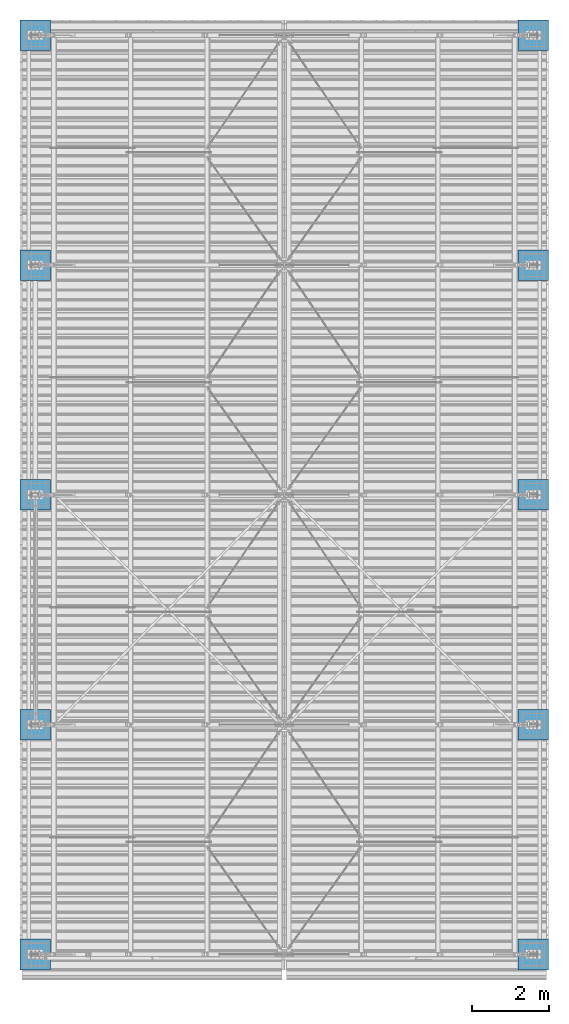
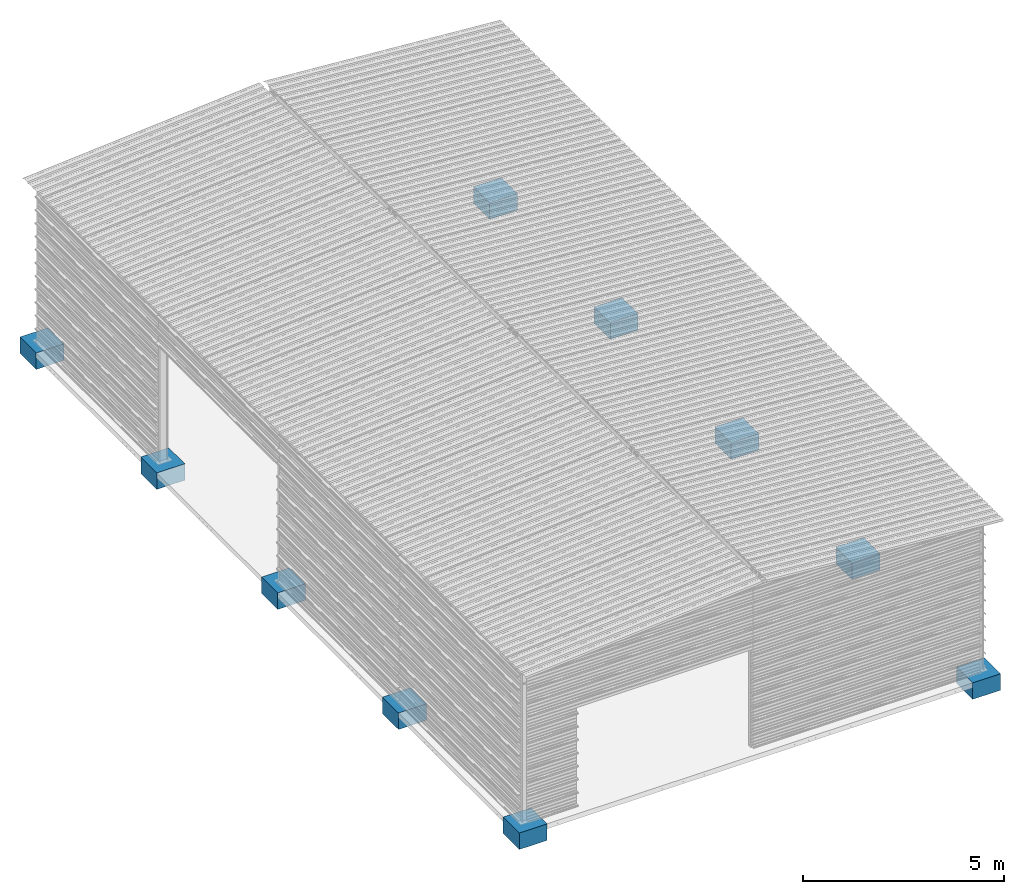
# One storey, part 1 of 70: 10 footings, 10 elements without a shape of their own.
"""IFC2X3 building model written with IfcOpenShell, lengths in millimetres."""

import ifcopenshell
import ifcopenshell.guid

model = None  # the IFC model being written
_history = None  # IfcOwnerHistory: only IFC2X3 demands one
_inside = {}  # id of a spatial element -> (the spatial element, [elements in it])
_under = {}  # id of a project, library or spatial element -> (it, [spatial elements below it])
_declared = {}  # id of a project -> (the project, [libraries it declares])
_typed = {}  # id of a type object -> (the type object, [elements of that type])
_made_of = {}  # id of a material, layer set ... -> (it, [elements and type objects made of it])


def new_model(schema):
    """Start an empty IFC model of exactly this schema.

    Asked for "IFC4X3", IfcOpenShell would pick the latest addendum, in which some entities
    have other attributes; the version numbers below select the first issue.
    IFC2X3 requires an IfcOwnerHistory on every rooted entity: one is made here for all.
    """
    global model, _history
    if schema == "IFC4X3":
        model = ifcopenshell.file(schema_version=(4, 3, 0, 0))
    else:
        model = ifcopenshell.file(schema=schema)
    _inside.clear()
    _under.clear()
    _declared.clear()
    _typed.clear()
    _made_of.clear()
    _history = None
    if model.schema == "IFC2X3":
        org = make("IfcOrganization", Name="unknown")
        user = make(
            "IfcPersonAndOrganization",
            ThePerson=make("IfcPerson", FamilyName="unknown"),
            TheOrganization=org,
        )
        app = make(
            "IfcApplication",
            ApplicationDeveloper=org,
            Version="unknown",
            ApplicationFullName="unknown",
            ApplicationIdentifier="unknown",
        )
        _history = make(
            "IfcOwnerHistory",
            OwningUser=user,
            OwningApplication=app,
            ChangeAction="ADDED",
            CreationDate=0,
        )
    return model


def make(cls, **values):
    """One entity of the class cls with the attributes given. An attribute that is None is left unset."""
    return model.create_entity(
        cls, **{name: value for name, value in values.items() if value is not None}
    )


def rooted(cls, **values):
    """An entity with a GlobalId (a new one), such as an element, a storey or a relation."""
    return make(cls, GlobalId=ifcopenshell.guid.new(), OwnerHistory=_history, **values)


def si_unit(unit_type, name, prefix=None):
    """IfcSIUnit, for example si_unit("LENGTHUNIT", "METRE", prefix="MILLI")."""
    return make("IfcSIUnit", UnitType=unit_type, Prefix=prefix, Name=name)


def assignment(units):
    """IfcUnitAssignment: the units of a project."""
    return None if units is None else make("IfcUnitAssignment", Units=units)


def point(xyz):
    """IfcCartesianPoint."""
    return None if xyz is None else make("IfcCartesianPoint", Coordinates=xyz)


def direction(xyz):
    """IfcDirection."""
    return None if xyz is None else make("IfcDirection", DirectionRatios=xyz)


def frame(location, z_axis=None, x_axis=None):
    """IfcAxis2Placement3D, a coordinate frame: its origin and axes. An axis left out is left unset."""
    return make(
        "IfcAxis2Placement3D",
        Location=point(location),
        Axis=direction(z_axis),
        RefDirection=direction(x_axis),
    )


def frame_2d(location, x_axis=None):
    """IfcAxis2Placement2D, a coordinate frame in the plane: its origin and x axis."""
    return make(
        "IfcAxis2Placement2D", Location=point(location), RefDirection=direction(x_axis)
    )


def origin_with_axes():
    """The frame at (0, 0, 0) with the z axis (0, 0, 1) and the x axis (1, 0, 0) written out."""
    return frame((0.0, 0.0, 0.0), z_axis=(0.0, 0.0, 1.0), x_axis=(1.0, 0.0, 0.0))


def origin_2d_with_axis():
    """The frame at (0, 0) in the plane with the x axis (1, 0) written out."""
    return frame_2d((0.0, 0.0), x_axis=(1.0, 0.0))


def place(relative_to, where):
    """IfcLocalPlacement: puts the frame where relative to a parent placement (None: the world)."""
    return make(
        "IfcLocalPlacement", PlacementRelTo=relative_to, RelativePlacement=where
    )


def context(
    kind, dimensions, precision=None, world=None, true_north=None, identifier=None
):
    """IfcGeometricRepresentationContext, for example the 3D "Model" context."""
    return make(
        "IfcGeometricRepresentationContext",
        ContextIdentifier=identifier,
        ContextType=kind,
        CoordinateSpaceDimension=dimensions,
        Precision=precision,
        WorldCoordinateSystem=world,
        TrueNorth=true_north,
    )


def subcontext(parent, identifier, kind, view, scale=None):
    """IfcGeometricRepresentationSubContext, for example "Body" below "Model"."""
    return make(
        "IfcGeometricRepresentationSubContext",
        ContextIdentifier=identifier,
        ContextType=kind,
        ParentContext=parent,
        TargetScale=scale,
        TargetView=view,
    )


def project(units=None, contexts=None):
    """IfcProject with its units and contexts."""
    return rooted(
        "IfcProject",
        Name="project",
        RepresentationContexts=contexts,
        UnitsInContext=assignment(units),
    )


def spatial(cls, under=None, at=None, **own):
    """A site, building, storey or space (cls), placed at a placement, below another one or the project."""
    s = rooted(cls, ObjectPlacement=at, **own)
    if under is not None:
        _under.setdefault(under.id(), (under, []))[1].append(s)
    return s


def profile(cls, at=None, kind="AREA", **sizes):
    """A parametric profile (cls). Its sizes go by their IFC names, for example OverallWidth=200.0."""
    return make(cls, ProfileType=kind, Position=at, **sizes)


def rectangle(**sizes):
    """IfcRectangleProfileDef."""
    return profile("IfcRectangleProfileDef", **sizes)


def extrude(swept, where, along, depth):
    """IfcExtrudedAreaSolid: the profile swept, set in the frame where, extruded along a direction by depth."""
    return make(
        "IfcExtrudedAreaSolid",
        SweptArea=swept,
        Position=where,
        ExtrudedDirection=direction(along),
        Depth=depth,
    )


def shape(context_of_items, identifier, shape_type, items):
    """IfcShapeRepresentation: the items that make up one representation, for example the "Body"."""
    return make(
        "IfcShapeRepresentation",
        ContextOfItems=context_of_items,
        RepresentationIdentifier=identifier,
        RepresentationType=shape_type,
        Items=items,
    )


def material(Name=None, Category=None):
    """IfcMaterial."""
    return make("IfcMaterial", Name=Name, Category=Category)


def made_of(thing, what):
    """Note that an element or type object is made of a material, layer set ...; save() writes the relation."""
    if what is not None:
        _made_of.setdefault(what.id(), (what, []))[1].append(thing)
    return thing


def element(
    cls,
    number,
    at=None,
    inside=None,
    cuts=None,
    type_object=None,
    material=None,
    context=None,
    identifier="Body",
    shape_type=None,
    held_by="IfcProductDefinitionShape",
    body=None,
    shapes=None,
    **own,
):
    """One element of the class cls, such as IfcWall. Its Tag is "e" and its number.

    at: its placement. inside: the storey or other place that contains it. cuts: it is an
    opening in that element (IfcRelVoidsElement). A single representation is given by context,
    identifier, shape_type and body (its items); several are given by shapes. held_by: the class
    of the entity that holds the representations. save() writes the other relations.
    """
    e = rooted(cls, Tag="e%d" % number, ObjectPlacement=at, **own)
    if body is not None:
        shapes = [shape(context, identifier, shape_type, body)]
    if shapes is not None:
        e.Representation = make(held_by, Representations=shapes)
    if inside is not None:
        _inside.setdefault(inside.id(), (inside, []))[1].append(e)
    if cuts is not None:
        rooted(
            "IfcRelVoidsElement", RelatingBuildingElement=cuts, RelatedOpeningElement=e
        )
    if type_object is not None:
        _typed.setdefault(type_object.id(), (type_object, []))[1].append(e)
    return made_of(e, material)


def aggregate(whole, parts):
    """IfcRelAggregates: a whole, such as a stair, and the parts it consists of."""
    return rooted("IfcRelAggregates", RelatingObject=whole, RelatedObjects=parts)


def save(model, path):
    """Write the relations noted so far, then the file.

    IfcRelAggregates (storeys below a building ...), IfcRelContainedInSpatialStructure (elements
    in a storey), IfcRelDefinesByType, IfcRelAssociatesMaterial and IfcRelDeclares: one each for
    every whole, place, type object, material and project.
    """
    for whole, parts in _under.values():
        aggregate(whole, parts)
    for where, things in _inside.values():
        rooted(
            "IfcRelContainedInSpatialStructure",
            RelatedElements=things,
            RelatingStructure=where,
        )
    for kind, things in _typed.values():
        rooted("IfcRelDefinesByType", RelatedObjects=things, RelatingType=kind)
    for what, things in _made_of.values():
        rooted("IfcRelAssociatesMaterial", RelatedObjects=things, RelatingMaterial=what)
    for by, libraries in _declared.values():
        rooted("IfcRelDeclares", RelatingContext=by, RelatedDefinitions=libraries)
    model.write(path)


model = new_model("IFC2X3")

# Units and contexts
model_context = context("Model", 3, precision=1e-05, world=origin_with_axes())
body_context = subcontext(model_context, "Body", "Model", "MODEL_VIEW")
ifc_project = project(units=[si_unit("LENGTHUNIT", "METRE", prefix="MILLI"), si_unit("AREAUNIT", "SQUARE_METRE"), si_unit("VOLUMEUNIT", "CUBIC_METRE"), si_unit("MASSUNIT", "GRAM", prefix="KILO"), si_unit("TIMEUNIT", "SECOND"), si_unit("PLANEANGLEUNIT", "RADIAN"), si_unit("SOLIDANGLEUNIT", "STERADIAN"), si_unit("THERMODYNAMICTEMPERATUREUNIT", "DEGREE_CELSIUS"), si_unit("LUMINOUSINTENSITYUNIT", "LUMEN")], contexts=[model_context])

# Site, building, storey
site_placement = place(None, origin_with_axes())
site = spatial("IfcSite", under=ifc_project, at=site_placement, CompositionType="ELEMENT")
building_placement = place(site_placement, origin_with_axes())
building = spatial("IfcBuilding", under=site, at=building_placement, Name="Undefined", CompositionType="ELEMENT")
storey_placement = place(building_placement, origin_with_axes())
storey = spatial("IfcBuildingStorey", under=building, at=storey_placement, Name="Undefined", CompositionType="ELEMENT", Elevation=0.0)

# Assembly, footing
assembly_1_placement = place(storey_placement, origin_with_axes())
assembly_1 = element("IfcElementAssembly", 1, at=assembly_1_placement, inside=storey, Name="SEMELLE", AssemblyPlace="NOTDEFINED", PredefinedType="REINFORCEMENT_UNIT")
ifc_material = material(Name="CONCRETE/C20/25")
footing_1_placement = place(assembly_1_placement, frame((4.54747350886464e-13, 2.1818607365276e-08, -510.0), z_axis=(0.0, -1.0, 0.0), x_axis=(0.0, 0.0, 1.0)))
footing_1 = element("IfcFooting", 2, at=footing_1_placement, material=ifc_material, Name="SEMELLE", PredefinedType="NOTDEFINED", context=body_context, shape_type="SweptSolid", body=[
    extrude(rectangle(XDim=800.0, YDim=800.0, at=origin_2d_with_axis()), frame((500.0, 0.0, 0.0), z_axis=(-1.0, 0.0, 0.0), x_axis=(0.0, -1.0, 0.0)), (0.0, 0.0, 1.0), 500.0),
])
aggregate(assembly_1, [footing_1])

assembly_2_placement = place(storey_placement, origin_with_axes())
assembly_2 = element("IfcElementAssembly", 3, at=assembly_2_placement, inside=storey, Name="SEMELLE", AssemblyPlace="NOTDEFINED", PredefinedType="REINFORCEMENT_UNIT")
footing_2_placement = place(assembly_2_placement, frame((13000.0, 24000.0, -509.999999978161), z_axis=(0.0, -1.0, 0.0), x_axis=(0.0, 0.0, 1.0)))
footing_2 = element("IfcFooting", 4, at=footing_2_placement, material=ifc_material, Name="SEMELLE", PredefinedType="NOTDEFINED", context=body_context, shape_type="SweptSolid", body=[
    extrude(rectangle(XDim=800.0, YDim=800.0, at=origin_2d_with_axis()), frame((500.0, 0.0, 0.0), z_axis=(-1.0, 0.0, 0.0), x_axis=(0.0, -1.0, 0.0)), (0.0, 0.0, 1.0), 500.0),
])
aggregate(assembly_2, [footing_2])

assembly_3_placement = place(storey_placement, origin_with_axes())
assembly_3 = element("IfcElementAssembly", 5, at=assembly_3_placement, inside=storey, Name="SEMELLE", AssemblyPlace="NOTDEFINED", PredefinedType="REINFORCEMENT_UNIT")
footing_3_placement = place(assembly_3_placement, frame((13000.0, 18000.0, -509.999999978165), z_axis=(0.0, -1.0, 0.0), x_axis=(0.0, 0.0, 1.0)))
footing_3 = element("IfcFooting", 6, at=footing_3_placement, material=ifc_material, Name="SEMELLE", PredefinedType="NOTDEFINED", context=body_context, shape_type="SweptSolid", body=[
    extrude(rectangle(XDim=800.0, YDim=800.0, at=origin_2d_with_axis()), frame((500.0, 0.0, 0.0), z_axis=(-1.0, 0.0, 0.0), x_axis=(0.0, -1.0, 0.0)), (0.0, 0.0, 1.0), 500.0),
])
aggregate(assembly_3, [footing_3])

assembly_4_placement = place(storey_placement, origin_with_axes())
assembly_4 = element("IfcElementAssembly", 7, at=assembly_4_placement, inside=storey, Name="SEMELLE", AssemblyPlace="NOTDEFINED", PredefinedType="REINFORCEMENT_UNIT")
footing_4_placement = place(assembly_4_placement, frame((13000.0, 12000.0, -509.999999978167), z_axis=(0.0, -1.0, 0.0), x_axis=(0.0, 0.0, 1.0)))
footing_4 = element("IfcFooting", 8, at=footing_4_placement, material=ifc_material, Name="SEMELLE", PredefinedType="NOTDEFINED", context=body_context, shape_type="SweptSolid", body=[
    extrude(rectangle(XDim=800.0, YDim=800.0, at=origin_2d_with_axis()), frame((500.0, 0.0, 0.0), z_axis=(-1.0, 0.0, 0.0), x_axis=(0.0, -1.0, 0.0)), (0.0, 0.0, 1.0), 500.0),
])
aggregate(assembly_4, [footing_4])

assembly_5_placement = place(storey_placement, origin_with_axes())
assembly_5 = element("IfcElementAssembly", 9, at=assembly_5_placement, inside=storey, Name="SEMELLE", AssemblyPlace="NOTDEFINED", PredefinedType="REINFORCEMENT_UNIT")
footing_5_placement = place(assembly_5_placement, frame((13000.0000000272, 6000.00000002965, -510.0), z_axis=(0.0, -1.0, 0.0), x_axis=(0.0, 0.0, 1.0)))
footing_5 = element("IfcFooting", 10, at=footing_5_placement, material=ifc_material, Name="SEMELLE", PredefinedType="NOTDEFINED", context=body_context, shape_type="SweptSolid", body=[
    extrude(rectangle(XDim=800.0, YDim=800.0, at=origin_2d_with_axis()), frame((500.0, 0.0, 0.0), z_axis=(-1.0, 0.0, 0.0), x_axis=(0.0, -1.0, 0.0)), (0.0, 0.0, 1.0), 500.0),
])
aggregate(assembly_5, [footing_5])

assembly_6_placement = place(storey_placement, origin_with_axes())
assembly_6 = element("IfcElementAssembly", 11, at=assembly_6_placement, inside=storey, Name="SEMELLE", AssemblyPlace="NOTDEFINED", PredefinedType="REINFORCEMENT_UNIT")
footing_6_placement = place(assembly_6_placement, frame((13000.0000000272, 0.0, -510.0), z_axis=(0.0, -1.0, 0.0), x_axis=(0.0, 0.0, 1.0)))
footing_6 = element("IfcFooting", 12, at=footing_6_placement, material=ifc_material, Name="SEMELLE", PredefinedType="NOTDEFINED", context=body_context, shape_type="SweptSolid", body=[
    extrude(rectangle(XDim=800.0, YDim=800.0, at=origin_2d_with_axis()), frame((500.0, 0.0, 0.0), z_axis=(-1.0, 0.0, 0.0), x_axis=(0.0, -1.0, 0.0)), (0.0, 0.0, 1.0), 500.0),
])
aggregate(assembly_6, [footing_6])

assembly_7_placement = place(storey_placement, origin_with_axes())
assembly_7 = element("IfcElementAssembly", 13, at=assembly_7_placement, inside=storey, Name="SEMELLE", AssemblyPlace="NOTDEFINED", PredefinedType="REINFORCEMENT_UNIT")
footing_7_placement = place(assembly_7_placement, frame((5.00222085975111e-12, 24000.0000000218, -510.0), z_axis=(0.0, -1.0, 0.0), x_axis=(0.0, 0.0, 1.0)))
footing_7 = element("IfcFooting", 14, at=footing_7_placement, material=ifc_material, Name="SEMELLE", PredefinedType="NOTDEFINED", context=body_context, shape_type="SweptSolid", body=[
    extrude(rectangle(XDim=800.0, YDim=800.0, at=origin_2d_with_axis()), frame((500.0, 0.0, 0.0), z_axis=(-1.0, 0.0, 0.0), x_axis=(0.0, -1.0, 0.0)), (0.0, 0.0, 1.0), 500.0),
])
aggregate(assembly_7, [footing_7])

assembly_8_placement = place(storey_placement, origin_with_axes())
assembly_8 = element("IfcElementAssembly", 15, at=assembly_8_placement, inside=storey, Name="SEMELLE", AssemblyPlace="NOTDEFINED", PredefinedType="REINFORCEMENT_UNIT")
footing_8_placement = place(assembly_8_placement, frame((1.36424205265939e-12, 18000.0000000218, -510.0), z_axis=(0.0, -1.0, 0.0), x_axis=(0.0, 0.0, 1.0)))
footing_8 = element("IfcFooting", 16, at=footing_8_placement, material=ifc_material, Name="SEMELLE", PredefinedType="NOTDEFINED", context=body_context, shape_type="SweptSolid", body=[
    extrude(rectangle(XDim=800.0, YDim=800.0, at=origin_2d_with_axis()), frame((500.0, 0.0, 0.0), z_axis=(-1.0, 0.0, 0.0), x_axis=(0.0, -1.0, 0.0)), (0.0, 0.0, 1.0), 500.0),
])
aggregate(assembly_8, [footing_8])

assembly_9_placement = place(storey_placement, origin_with_axes())
assembly_9 = element("IfcElementAssembly", 17, at=assembly_9_placement, inside=storey, Name="SEMELLE", AssemblyPlace="NOTDEFINED", PredefinedType="REINFORCEMENT_UNIT")
footing_9_placement = place(assembly_9_placement, frame((1.36424205265939e-12, 12000.0000000218, -510.0), z_axis=(0.0, -1.0, 0.0), x_axis=(0.0, 0.0, 1.0)))
footing_9 = element("IfcFooting", 18, at=footing_9_placement, material=ifc_material, Name="SEMELLE", PredefinedType="NOTDEFINED", context=body_context, shape_type="SweptSolid", body=[
    extrude(rectangle(XDim=800.0, YDim=800.0, at=origin_2d_with_axis()), frame((500.0, 0.0, 0.0), z_axis=(-1.0, 0.0, 0.0), x_axis=(0.0, -1.0, 0.0)), (0.0, 0.0, 1.0), 500.0),
])
aggregate(assembly_9, [footing_9])

assembly_10_placement = place(storey_placement, origin_with_axes())
assembly_10 = element("IfcElementAssembly", 19, at=assembly_10_placement, inside=storey, Name="SEMELLE", AssemblyPlace="NOTDEFINED", PredefinedType="REINFORCEMENT_UNIT")
footing_10_placement = place(assembly_10_placement, frame((4.54747350886464e-13, 6000.00000002182, -510.0), z_axis=(0.0, -1.0, 0.0), x_axis=(0.0, 0.0, 1.0)))
footing_10 = element("IfcFooting", 20, at=footing_10_placement, material=ifc_material, Name="SEMELLE", PredefinedType="NOTDEFINED", context=body_context, shape_type="SweptSolid", body=[
    extrude(rectangle(XDim=800.0, YDim=800.0, at=origin_2d_with_axis()), frame((500.0, 0.0, 0.0), z_axis=(-1.0, 0.0, 0.0), x_axis=(0.0, -1.0, 0.0)), (0.0, 0.0, 1.0), 500.0),
])
aggregate(assembly_10, [footing_10])

save(model, "model.ifc")
